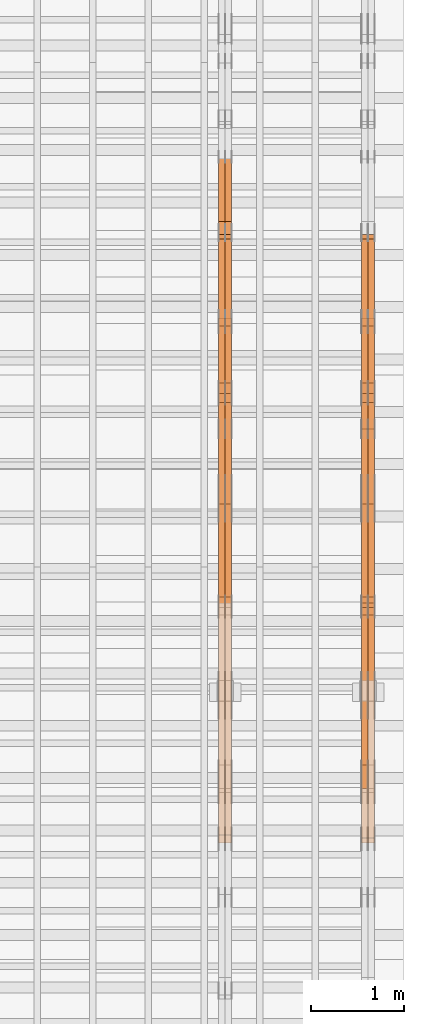
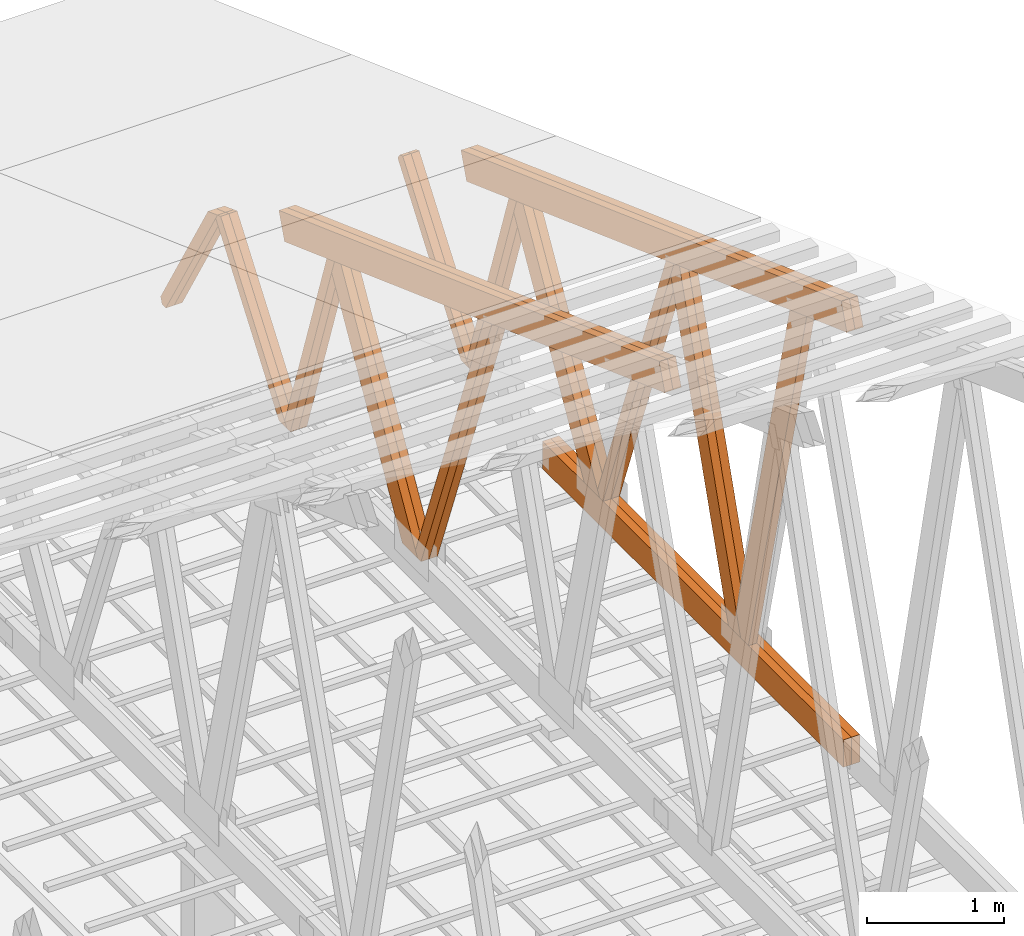
# One storey, part 65 of 189: 27 proxies.
"""IFC2X3 building model written with IfcOpenShell, lengths in millimetres."""

from ifc_helpers import new_model, entity, si_unit, converted_unit, derived_unit, direction, frame, origin, origin_2d_with_axis, place, context, subcontext, project, spatial, polyline, rectangle, outline, extrude, source, transform, mapped, material, type_object, type_shapes, element, save


model = new_model("IFC2X3")

# Units and contexts
model_context = context("Model", 3, precision=0.01, world=origin(), true_north=direction((6.12303176911189e-17, 1.0)))
body_context = subcontext(model_context, "Body", "Model", "MODEL_VIEW")
ifc_project = project(units=[si_unit("LENGTHUNIT", "METRE", prefix="MILLI"), si_unit("AREAUNIT", "SQUARE_METRE"), si_unit("VOLUMEUNIT", "CUBIC_METRE"), converted_unit("PLANEANGLEUNIT", "DEGREE", entity("IfcRatioMeasure", 0.0174532925199433), si_unit("PLANEANGLEUNIT", "RADIAN"), dimensions=[0, 0, 0, 0, 0, 0, 0]), si_unit("MASSUNIT", "GRAM", prefix="KILO"), derived_unit("MASSDENSITYUNIT", [(si_unit("MASSUNIT", "GRAM", prefix="KILO"), 1), (si_unit("LENGTHUNIT", "METRE"), -3)]), si_unit("TIMEUNIT", "SECOND"), si_unit("FREQUENCYUNIT", "HERTZ"), si_unit("THERMODYNAMICTEMPERATUREUNIT", "DEGREE_CELSIUS"), derived_unit("THERMALTRANSMITTANCEUNIT", [(si_unit("MASSUNIT", "GRAM", prefix="KILO"), 1), (si_unit("THERMODYNAMICTEMPERATUREUNIT", "KELVIN"), -1), (si_unit("TIMEUNIT", "SECOND"), -3)]), derived_unit("VOLUMETRICFLOWRATEUNIT", [(si_unit("LENGTHUNIT", "METRE"), 3), (si_unit("TIMEUNIT", "SECOND"), -1)]), si_unit("ELECTRICCURRENTUNIT", "AMPERE"), si_unit("ELECTRICVOLTAGEUNIT", "VOLT"), si_unit("POWERUNIT", "WATT"), si_unit("FORCEUNIT", "NEWTON"), si_unit("ILLUMINANCEUNIT", "LUX"), si_unit("LUMINOUSFLUXUNIT", "LUMEN"), si_unit("LUMINOUSINTENSITYUNIT", "CANDELA"), derived_unit("USERDEFINED", [(si_unit("MASSUNIT", "GRAM", prefix="KILO"), -1), (si_unit("LENGTHUNIT", "METRE"), -2), (si_unit("TIMEUNIT", "SECOND"), 3), (si_unit("LUMINOUSFLUXUNIT", "LUMEN"), 1)]), derived_unit("LINEARVELOCITYUNIT", [(si_unit("LENGTHUNIT", "METRE"), 1), (si_unit("TIMEUNIT", "SECOND"), -1)]), si_unit("PRESSUREUNIT", "PASCAL"), derived_unit("USERDEFINED", [(si_unit("LENGTHUNIT", "METRE"), -2), (si_unit("MASSUNIT", "GRAM", prefix="KILO"), 1), (si_unit("TIMEUNIT", "SECOND"), -2)])], contexts=[model_context])

# Site, building, storey
site_placement = place(None, origin())
site = spatial("IfcSite", under=ifc_project, at=site_placement, CompositionType="ELEMENT")
building_placement = place(site_placement, origin())
building = spatial("IfcBuilding", under=site, at=building_placement, CompositionType="ELEMENT")
storey_placement = place(building_placement, origin())
storey = spatial("IfcBuildingStorey", under=building, at=storey_placement, Name="Default", CompositionType="ELEMENT", Elevation=0.0)

# Proxies
ifc_material_1 = material(Name="IfcSurfaceStyle #272650")
building_element_proxy_type_1 = type_object("IfcBuildingElementProxyType", Name="T1-W1 272648", PredefinedType="NOTDEFINED", material=ifc_material_1)
shared_shape_1 = source(origin(), body_context, "Body", "SweptSolid", [
    extrude(outline(polyline([(-1996.99427801396, -109.999889649051), (1271.09905152223, -109.999889649051), (1448.88120817726, -0.000113190727324008), (1421.70802776002, 109.999946244415), (-2144.69400944554, 109.999946244415), (-1996.99427801396, -109.999889649051)])), frame((1448.88120817726, 110.000265670598, 0.0), z_axis=(0.0, 0.0, 1.0), x_axis=(-1.0, 0.0, 0.0)), (0.0, 0.0, 1.0), 69.9999999999998),
])
type_shapes(building_element_proxy_type_1, [shared_shape_1])
proxy_1_placement = place(building_placement, frame((49770.0, 20558.6774904859, 218.61972674968), z_axis=(-1.0, 0.0, 0.0), x_axis=(0.0, -0.239819839925979, 0.970817410421691)))
element("IfcBuildingElementProxy", 1, at=proxy_1_placement, inside=storey, type_object=building_element_proxy_type_1, material=ifc_material_1, Name="T1-W1", context=body_context, shape_type="MappedRepresentation", body=[
    mapped(shared_shape_1, transform((0.0, 0.0, 0.0), scale=1.0)),
])
ifc_material_2 = material(Name="IfcSurfaceStyle #272452")
building_element_proxy_type_2 = type_object("IfcBuildingElementProxyType", Name="T1-W4 272450", PredefinedType="NOTDEFINED", material=ifc_material_2)
shared_shape_2 = source(origin(), body_context, "Body", "SweptSolid", [
    extrude(outline(polyline([(-1742.90513395849, -84.9997422414737), (1181.3544167489, -84.9997422414737), (1178.19398821251, -0.000208932978430543), (1071.44989130457, 84.999846707963), (-1688.09316230749, 84.999846707963), (-1742.90513395849, -84.9997422414737)])), frame((1181.35452116422, 84.999886337523, 0.0), z_axis=(0.0, 0.0, 1.0), x_axis=(-1.0, 0.0, 0.0)), (0.0, 0.0, 1.0), 69.9999999999998),
])
type_shapes(building_element_proxy_type_2, [shared_shape_2])
proxy_2_placement = place(building_placement, frame((49840.0, 21724.6281517871, 2976.00232464744), z_axis=(-1.0, 0.0, 0.0), x_axis=(0.0, -0.306868406216495, -0.951751953644514)))
element("IfcBuildingElementProxy", 2, at=proxy_2_placement, inside=storey, type_object=building_element_proxy_type_2, material=ifc_material_2, Name="T1-W4", context=body_context, shape_type="MappedRepresentation", body=[
    mapped(shared_shape_2, transform((0.0, 0.0, 0.0), scale=1.0)),
])
ifc_material_3 = material(Name="IfcSurfaceStyle #272386")
building_element_proxy_type_3 = type_object("IfcBuildingElementProxyType", Name="T1-W4 272384", PredefinedType="NOTDEFINED", material=ifc_material_3)
shared_shape_3 = source(origin(), body_context, "Body", "SweptSolid", [
    extrude(outline(polyline([(-1742.90513395849, -84.9997422414737), (1181.3544167489, -84.9997422414737), (1178.19398821251, -0.000208932978430543), (1071.44989130457, 84.999846707963), (-1688.09316230749, 84.999846707963), (-1742.90513395849, -84.9997422414737)])), frame((1181.35452116422, 84.999886337523, 0.0), z_axis=(0.0, 0.0, 1.0), x_axis=(-1.0, 0.0, 0.0)), (0.0, 0.0, 1.0), 69.9999999999998),
])
type_shapes(building_element_proxy_type_3, [shared_shape_3])
proxy_3_placement = place(building_placement, frame((49770.0, 21724.6281517871, 2976.00232464744), z_axis=(-1.0, 0.0, 0.0), x_axis=(0.0, -0.306868406216495, -0.951751953644514)))
element("IfcBuildingElementProxy", 3, at=proxy_3_placement, inside=storey, type_object=building_element_proxy_type_3, material=ifc_material_3, Name="T1-W4", context=body_context, shape_type="MappedRepresentation", body=[
    mapped(shared_shape_3, transform((0.0, 0.0, 0.0), scale=1.0)),
])
ifc_material_4 = material(Name="IfcSurfaceStyle #272188")
building_element_proxy_type_4 = type_object("IfcBuildingElementProxyType", Name="T1-W8 272186", PredefinedType="NOTDEFINED", material=ifc_material_4)
shared_shape_4 = source(origin(), body_context, "Body", "SweptSolid", [
    extrude(outline(polyline([(-1700.10906247918, -47.4998559987011), (1140.60243146647, -47.4998559987011), (1179.56122089033, 0.000120838919977206), (1161.65086478184, 47.4997955792411), (-1781.70545465947, 47.4997955792411), (-1700.10906247918, -47.4998559987011)])), frame((1179.56128464708, 47.5000634692093, 0.0), z_axis=(0.0, 0.0, 1.0), x_axis=(-1.0, 0.0, 0.0)), (0.0, 0.0, 1.0), 69.9999999999998),
])
type_shapes(building_element_proxy_type_4, [shared_shape_4])
proxy_4_placement = place(building_placement, frame((49840.0, 22687.5385403115, 228.241249073207), z_axis=(-1.0, 0.0, 0.0), x_axis=(0.0, -0.352814979177604, 0.93569310698963)))
element("IfcBuildingElementProxy", 4, at=proxy_4_placement, inside=storey, type_object=building_element_proxy_type_4, material=ifc_material_4, Name="T1-W8", context=body_context, shape_type="MappedRepresentation", body=[
    mapped(shared_shape_4, transform((0.0, 0.0, 0.0), scale=1.0)),
])
ifc_material_5 = material(Name="IfcSurfaceStyle #272122")
building_element_proxy_type_5 = type_object("IfcBuildingElementProxyType", Name="T1-W8 272120", PredefinedType="NOTDEFINED", material=ifc_material_5)
shared_shape_5 = source(origin(), body_context, "Body", "SweptSolid", [
    extrude(outline(polyline([(-1700.10906247918, -47.4998559987011), (1140.60243146647, -47.4998559987011), (1179.56122089033, 0.000120838919977206), (1161.65086478184, 47.4997955792411), (-1781.70545465947, 47.4997955792411), (-1700.10906247918, -47.4998559987011)])), frame((1179.56128464708, 47.5000634692093, 0.0), z_axis=(0.0, 0.0, 1.0), x_axis=(-1.0, 0.0, 0.0)), (0.0, 0.0, 1.0), 69.9999999999998),
])
type_shapes(building_element_proxy_type_5, [shared_shape_5])
proxy_5_placement = place(building_placement, frame((49770.0, 22687.5385403115, 228.241249073207), z_axis=(-1.0, 0.0, 0.0), x_axis=(0.0, -0.352814979177604, 0.93569310698963)))
element("IfcBuildingElementProxy", 5, at=proxy_5_placement, inside=storey, type_object=building_element_proxy_type_5, material=ifc_material_5, Name="T1-W8", context=body_context, shape_type="MappedRepresentation", body=[
    mapped(shared_shape_5, transform((0.0, 0.0, 0.0), scale=1.0)),
])
ifc_material_6 = material(Name="IfcSurfaceStyle #271924")
building_element_proxy_type_6 = type_object("IfcBuildingElementProxyType", Name="T1-W2 271922", PredefinedType="NOTDEFINED", material=ifc_material_6)
shared_shape_6 = source(origin(), body_context, "Body", "SweptSolid", [
    extrude(outline(polyline([(-1361.89144606429, -97.5000598486876), (887.613245225805, -97.5000598486876), (904.774262962339, 0.000302345139042259), (818.892339969004, 97.4999086761182), (-1249.38840209286, 97.4999086761182), (-1361.89144606429, -97.5000598486876)])), frame((904.774262962339, 97.5000966763391, 0.0), z_axis=(0.0, 0.0, 1.0), x_axis=(-1.0, 0.0, 0.0)), (0.0, 0.0, 1.0), 69.9999999999999),
])
type_shapes(building_element_proxy_type_6, [shared_shape_6])
proxy_6_placement = place(building_placement, frame((49840.0, 24033.6159173732, 2110.89189244614), z_axis=(-1.0, 0.0, 0.0), x_axis=(0.0, -0.5, -0.866025403784439)))
element("IfcBuildingElementProxy", 6, at=proxy_6_placement, inside=storey, type_object=building_element_proxy_type_6, material=ifc_material_6, Name="T1-W2", context=body_context, shape_type="MappedRepresentation", body=[
    mapped(shared_shape_6, transform((0.0, 0.0, 0.0), scale=1.0)),
])
ifc_material_7 = material(Name="IfcSurfaceStyle #271858")
building_element_proxy_type_7 = type_object("IfcBuildingElementProxyType", Name="T1-W2 271856", PredefinedType="NOTDEFINED", material=ifc_material_7)
shared_shape_7 = source(origin(), body_context, "Body", "SweptSolid", [
    extrude(outline(polyline([(-1361.89144606429, -97.5000598486876), (887.613245225805, -97.5000598486876), (904.774262962339, 0.000302345139042259), (818.892339969004, 97.4999086761182), (-1249.38840209286, 97.4999086761182), (-1361.89144606429, -97.5000598486876)])), frame((904.774262962339, 97.5000966763391, 0.0), z_axis=(0.0, 0.0, 1.0), x_axis=(-1.0, 0.0, 0.0)), (0.0, 0.0, 1.0), 69.9999999999999),
])
type_shapes(building_element_proxy_type_7, [shared_shape_7])
proxy_7_placement = place(building_placement, frame((49770.0, 24033.6159173732, 2110.89189244614), z_axis=(-1.0, 0.0, 0.0), x_axis=(0.0, -0.5, -0.866025403784439)))
element("IfcBuildingElementProxy", 7, at=proxy_7_placement, inside=storey, type_object=building_element_proxy_type_7, material=ifc_material_7, Name="T1-W2", context=body_context, shape_type="MappedRepresentation", body=[
    mapped(shared_shape_7, transform((0.0, 0.0, 0.0), scale=1.0)),
])
ifc_material_8 = material(Name="IfcSurfaceStyle #271660")
building_element_proxy_type_8 = type_object("IfcBuildingElementProxyType", Name="T1-W9 271658", PredefinedType="NOTDEFINED", material=ifc_material_8)
shared_shape_8 = source(origin(), body_context, "Body", "SweptSolid", [
    extrude(outline(polyline([(-1151.44310138162, -47.5000079487596), (776.329826327547, -47.5000079487596), (809.267611644053, -8.1966354137375e-07), (793.242530238244, 47.5000083585914), (-1227.39686682822, 47.5000083585914), (-1151.44310138162, -47.5000079487596)])), frame((809.267685789073, 47.5000083585914, 0.0), z_axis=(0.0, 0.0, 1.0), x_axis=(-1.0, 0.0, 0.0)), (0.0, 0.0, 1.0), 69.9999999999999),
])
type_shapes(building_element_proxy_type_8, [shared_shape_8])
proxy_8_placement = place(building_placement, frame((49840.0, 24600.2198992919, 229.815691184017), z_axis=(-1.0, 0.0, 0.0), x_axis=(0.0, -0.31966811847134, 0.947529574226047)))
element("IfcBuildingElementProxy", 8, at=proxy_8_placement, inside=storey, type_object=building_element_proxy_type_8, material=ifc_material_8, Name="T1-W9", context=body_context, shape_type="MappedRepresentation", body=[
    mapped(shared_shape_8, transform((0.0, 0.0, 0.0), scale=1.0)),
])
ifc_material_9 = material(Name="IfcSurfaceStyle #271594")
building_element_proxy_type_9 = type_object("IfcBuildingElementProxyType", Name="T1-W9 271592", PredefinedType="NOTDEFINED", material=ifc_material_9)
shared_shape_9 = source(origin(), body_context, "Body", "SweptSolid", [
    extrude(outline(polyline([(-1151.44310138162, -47.5000079487596), (776.329826327547, -47.5000079487596), (809.267611644053, -8.1966354137375e-07), (793.242530238244, 47.5000083585914), (-1227.39686682822, 47.5000083585914), (-1151.44310138162, -47.5000079487596)])), frame((809.267685789073, 47.5000083585914, 0.0), z_axis=(0.0, 0.0, 1.0), x_axis=(-1.0, 0.0, 0.0)), (0.0, 0.0, 1.0), 69.9999999999999),
])
type_shapes(building_element_proxy_type_9, [shared_shape_9])
proxy_9_placement = place(building_placement, frame((49770.0, 24600.2198992919, 229.815691184017), z_axis=(-1.0, 0.0, 0.0), x_axis=(0.0, -0.31966811847134, 0.947529574226047)))
element("IfcBuildingElementProxy", 9, at=proxy_9_placement, inside=storey, type_object=building_element_proxy_type_9, material=ifc_material_9, Name="T1-W9", context=body_context, shape_type="MappedRepresentation", body=[
    mapped(shared_shape_9, transform((0.0, 0.0, 0.0), scale=1.0)),
])
ifc_material_10 = material(Name="IfcSurfaceStyle #271396")
building_element_proxy_type_10 = type_object("IfcBuildingElementProxyType", Name="T1-W10 271394", PredefinedType="NOTDEFINED", material=ifc_material_10)
shared_shape_10 = source(origin(), body_context, "Body", "SweptSolid", [
    extrude(outline(polyline([(-993.240970354386, -47.5000757607337), (635.890952815036, -47.5000757607337), (650.068145237537, -1.47580554758164e-05), (629.921374092803, 47.5000831397614), (-922.639501790989, 47.5000831397614), (-993.240970354386, -47.5000757607337)])), frame((650.068173419645, 47.5002811208496, 0.0), z_axis=(0.0, 0.0, 1.0), x_axis=(-1.0, 0.0, 0.0)), (0.0, 0.0, 1.0), 69.9999999999999),
])
type_shapes(building_element_proxy_type_10, [shared_shape_10])
proxy_10_placement = place(building_placement, frame((49840.0, 25701.688098798, 1507.2920009025), z_axis=(-1.0, 0.0, 0.0), x_axis=(0.0, -0.596486092002004, -0.802623412347395)))
element("IfcBuildingElementProxy", 10, at=proxy_10_placement, inside=storey, type_object=building_element_proxy_type_10, material=ifc_material_10, Name="T1-W10", context=body_context, shape_type="MappedRepresentation", body=[
    mapped(shared_shape_10, transform((0.0, 0.0, 0.0), scale=1.0)),
])
ifc_material_11 = material(Name="IfcSurfaceStyle #271330")
building_element_proxy_type_11 = type_object("IfcBuildingElementProxyType", Name="T1-W10 271328", PredefinedType="NOTDEFINED", material=ifc_material_11)
shared_shape_11 = source(origin(), body_context, "Body", "SweptSolid", [
    extrude(outline(polyline([(-993.240970354386, -47.5000757607337), (635.890952815036, -47.5000757607337), (650.068145237537, -1.47580554758164e-05), (629.921374092803, 47.5000831397614), (-922.639501790989, 47.5000831397614), (-993.240970354386, -47.5000757607337)])), frame((650.068173419645, 47.5002811208496, 0.0), z_axis=(0.0, 0.0, 1.0), x_axis=(-1.0, 0.0, 0.0)), (0.0, 0.0, 1.0), 69.9999999999999),
])
type_shapes(building_element_proxy_type_11, [shared_shape_11])
proxy_11_placement = place(building_placement, frame((49770.0, 25701.688098798, 1507.2920009025), z_axis=(-1.0, 0.0, 0.0), x_axis=(0.0, -0.596486092002004, -0.802623412347395)))
element("IfcBuildingElementProxy", 11, at=proxy_11_placement, inside=storey, type_object=building_element_proxy_type_11, material=ifc_material_11, Name="T1-W10", context=body_context, shape_type="MappedRepresentation", body=[
    mapped(shared_shape_11, transform((0.0, 0.0, 0.0), scale=1.0)),
])
ifc_material_12 = material(Name="IfcSurfaceStyle #269848")
building_element_proxy_type_12 = type_object("IfcBuildingElementProxyType", Name="T1-B4 269846", PredefinedType="NOTDEFINED", material=ifc_material_12)
shared_shape_12 = source(origin(), body_context, "Body", "SweptSolid", [
    extrude(rectangle(XDim=4408.2412109375, YDim=245.000000000001, at=origin_2d_with_axis()), frame((2204.12060546875, 122.5, 0.0), z_axis=(0.0, 0.0, 1.0), x_axis=(-1.0, 0.0, 0.0)), (0.0, 0.0, 1.0), 69.9999999999997),
])
type_shapes(building_element_proxy_type_12, [shared_shape_12])
proxy_12_placement = place(building_placement, frame((49840.0, 19161.7587890625, 245.0), z_axis=(-1.0, 0.0, 0.0), x_axis=(0.0, 1.0, 0.0)))
element("IfcBuildingElementProxy", 12, at=proxy_12_placement, inside=storey, type_object=building_element_proxy_type_12, material=ifc_material_12, Name="T1-B4", context=body_context, shape_type="MappedRepresentation", body=[
    mapped(shared_shape_12, transform((0.0, 0.0, 0.0), scale=1.0)),
])
ifc_material_13 = material(Name="IfcSurfaceStyle #269791")
building_element_proxy_type_13 = type_object("IfcBuildingElementProxyType", Name="T1-B4 269789", PredefinedType="NOTDEFINED", material=ifc_material_13)
shared_shape_13 = source(origin(), body_context, "Body", "SweptSolid", [
    extrude(rectangle(XDim=4408.2412109375, YDim=245.000000000001, at=origin_2d_with_axis()), frame((2204.12060546875, 122.5, 0.0), z_axis=(0.0, 0.0, 1.0), x_axis=(-1.0, 0.0, 0.0)), (0.0, 0.0, 1.0), 69.9999999999997),
])
type_shapes(building_element_proxy_type_13, [shared_shape_13])
proxy_13_placement = place(building_placement, frame((49770.0, 19161.7587890625, 245.0), z_axis=(-1.0, 0.0, 0.0), x_axis=(0.0, 1.0, 0.0)))
element("IfcBuildingElementProxy", 13, at=proxy_13_placement, inside=storey, type_object=building_element_proxy_type_13, material=ifc_material_13, Name="T1-B4", context=body_context, shape_type="MappedRepresentation", body=[
    mapped(shared_shape_13, transform((0.0, 0.0, 0.0), scale=1.0)),
])
ifc_material_14 = material(Name="IfcSurfaceStyle #268804")
building_element_proxy_type_14 = type_object("IfcBuildingElementProxyType", Name="T1-T1 268802", PredefinedType="NOTDEFINED", material=ifc_material_14)
shared_shape_14 = source(origin(), body_context, "Body", "SweptSolid", [
    extrude(outline(polyline([(-2964.99982426074, -122.499947708046), (2964.99981923522, -122.499947708046), (2964.99984513599, 122.499947708046), (-2964.99984011047, 122.499947708046), (-2964.99982426074, -122.499947708046)])), frame((2964.99984513599, 122.499998966405, 0.0), z_axis=(0.0, 0.0, 1.0), x_axis=(-1.0, 0.0, 0.0)), (0.0, 0.0, 1.0), 69.9999999999996),
])
type_shapes(building_element_proxy_type_14, [shared_shape_14])
proxy_14_placement = place(building_placement, frame((49840.0, 24681.3398262186, 1893.12531804384), z_axis=(-1.0, 0.0, 0.0), x_axis=(0.0, -0.939692620785908, 0.342020143325669)))
element("IfcBuildingElementProxy", 14, at=proxy_14_placement, inside=storey, type_object=building_element_proxy_type_14, material=ifc_material_14, Name="T1-T1", context=body_context, shape_type="MappedRepresentation", body=[
    mapped(shared_shape_14, transform((0.0, 0.0, 0.0), scale=1.0)),
])
ifc_material_15 = material(Name="IfcSurfaceStyle #268747")
building_element_proxy_type_15 = type_object("IfcBuildingElementProxyType", Name="T1-T1 268745", PredefinedType="NOTDEFINED", material=ifc_material_15)
shared_shape_15 = source(origin(), body_context, "Body", "SweptSolid", [
    extrude(outline(polyline([(-2964.99982426074, -122.499947708046), (2964.99981923522, -122.499947708046), (2964.99984513599, 122.499947708046), (-2964.99984011047, 122.499947708046), (-2964.99982426074, -122.499947708046)])), frame((2964.99984513599, 122.499998966405, 0.0), z_axis=(0.0, 0.0, 1.0), x_axis=(-1.0, 0.0, 0.0)), (0.0, 0.0, 1.0), 69.9999999999996),
])
type_shapes(building_element_proxy_type_15, [shared_shape_15])
proxy_15_placement = place(building_placement, frame((49770.0, 24681.3398262186, 1893.12531804384), z_axis=(-1.0, 0.0, 0.0), x_axis=(0.0, -0.939692620785908, 0.342020143325669)))
element("IfcBuildingElementProxy", 15, at=proxy_15_placement, inside=storey, type_object=building_element_proxy_type_15, material=ifc_material_15, Name="T1-T1", context=body_context, shape_type="MappedRepresentation", body=[
    mapped(shared_shape_15, transform((0.0, 0.0, 0.0), scale=1.0)),
])
ifc_material_16 = material(Name="IfcSurfaceStyle #256398")
building_element_proxy_type_16 = type_object("IfcBuildingElementProxyType", Name="T1-W8 256396", PredefinedType="NOTDEFINED", material=ifc_material_16)
shared_shape_16 = source(origin(), body_context, "Body", "SweptSolid", [
    extrude(outline(polyline([(-1700.10906247918, -47.4998559987011), (1140.60243146647, -47.4998559987011), (1179.56122089033, 0.000120838919977206), (1161.65086478184, 47.4997955792411), (-1781.70545465947, 47.4997955792411), (-1700.10906247918, -47.4998559987011)])), frame((1179.56128464708, 47.5000634692093, 0.0), z_axis=(0.0, 0.0, 1.0), x_axis=(-1.0, 0.0, 0.0)), (0.0, 0.0, 1.0), 69.9999999999998),
])
type_shapes(building_element_proxy_type_16, [shared_shape_16])
proxy_16_placement = place(building_placement, frame((48300.0, 22687.5385403115, 228.241249073207), z_axis=(-1.0, 0.0, 0.0), x_axis=(0.0, -0.352814979177604, 0.93569310698963)))
element("IfcBuildingElementProxy", 16, at=proxy_16_placement, inside=storey, type_object=building_element_proxy_type_16, material=ifc_material_16, Name="T1-W8", context=body_context, shape_type="MappedRepresentation", body=[
    mapped(shared_shape_16, transform((0.0, 0.0, 0.0), scale=1.0)),
])
ifc_material_17 = material(Name="IfcSurfaceStyle #256332")
building_element_proxy_type_17 = type_object("IfcBuildingElementProxyType", Name="T1-W8 256330", PredefinedType="NOTDEFINED", material=ifc_material_17)
shared_shape_17 = source(origin(), body_context, "Body", "SweptSolid", [
    extrude(outline(polyline([(-1700.10906247918, -47.4998559987011), (1140.60243146647, -47.4998559987011), (1179.56122089033, 0.000120838919977206), (1161.65086478184, 47.4997955792411), (-1781.70545465947, 47.4997955792411), (-1700.10906247918, -47.4998559987011)])), frame((1179.56128464708, 47.5000634692093, 0.0), z_axis=(0.0, 0.0, 1.0), x_axis=(-1.0, 0.0, 0.0)), (0.0, 0.0, 1.0), 69.9999999999998),
])
type_shapes(building_element_proxy_type_17, [shared_shape_17])
proxy_17_placement = place(building_placement, frame((48230.0, 22687.5385403115, 228.241249073207), z_axis=(-1.0, 0.0, 0.0), x_axis=(0.0, -0.352814979177604, 0.93569310698963)))
element("IfcBuildingElementProxy", 17, at=proxy_17_placement, inside=storey, type_object=building_element_proxy_type_17, material=ifc_material_17, Name="T1-W8", context=body_context, shape_type="MappedRepresentation", body=[
    mapped(shared_shape_17, transform((0.0, 0.0, 0.0), scale=1.0)),
])
ifc_material_18 = material(Name="IfcSurfaceStyle #256134")
building_element_proxy_type_18 = type_object("IfcBuildingElementProxyType", Name="T1-W2 256132", PredefinedType="NOTDEFINED", material=ifc_material_18)
shared_shape_18 = source(origin(), body_context, "Body", "SweptSolid", [
    extrude(outline(polyline([(-1361.89144606429, -97.5000598486876), (887.613245225805, -97.5000598486876), (904.774262962339, 0.000302345139042259), (818.892339969004, 97.4999086761182), (-1249.38840209286, 97.4999086761182), (-1361.89144606429, -97.5000598486876)])), frame((904.774262962339, 97.5000966763391, 0.0), z_axis=(0.0, 0.0, 1.0), x_axis=(-1.0, 0.0, 0.0)), (0.0, 0.0, 1.0), 69.9999999999999),
])
type_shapes(building_element_proxy_type_18, [shared_shape_18])
proxy_18_placement = place(building_placement, frame((48300.0, 24033.6159173732, 2110.89189244614), z_axis=(-1.0, 0.0, 0.0), x_axis=(0.0, -0.5, -0.866025403784439)))
element("IfcBuildingElementProxy", 18, at=proxy_18_placement, inside=storey, type_object=building_element_proxy_type_18, material=ifc_material_18, Name="T1-W2", context=body_context, shape_type="MappedRepresentation", body=[
    mapped(shared_shape_18, transform((0.0, 0.0, 0.0), scale=1.0)),
])
ifc_material_19 = material(Name="IfcSurfaceStyle #256068")
building_element_proxy_type_19 = type_object("IfcBuildingElementProxyType", Name="T1-W2 256066", PredefinedType="NOTDEFINED", material=ifc_material_19)
shared_shape_19 = source(origin(), body_context, "Body", "SweptSolid", [
    extrude(outline(polyline([(-1361.89144606429, -97.5000598486876), (887.613245225805, -97.5000598486876), (904.774262962339, 0.000302345139042259), (818.892339969004, 97.4999086761182), (-1249.38840209286, 97.4999086761182), (-1361.89144606429, -97.5000598486876)])), frame((904.774262962339, 97.5000966763391, 0.0), z_axis=(0.0, 0.0, 1.0), x_axis=(-1.0, 0.0, 0.0)), (0.0, 0.0, 1.0), 69.9999999999999),
])
type_shapes(building_element_proxy_type_19, [shared_shape_19])
proxy_19_placement = place(building_placement, frame((48230.0, 24033.6159173732, 2110.89189244614), z_axis=(-1.0, 0.0, 0.0), x_axis=(0.0, -0.5, -0.866025403784439)))
element("IfcBuildingElementProxy", 19, at=proxy_19_placement, inside=storey, type_object=building_element_proxy_type_19, material=ifc_material_19, Name="T1-W2", context=body_context, shape_type="MappedRepresentation", body=[
    mapped(shared_shape_19, transform((0.0, 0.0, 0.0), scale=1.0)),
])
ifc_material_20 = material(Name="IfcSurfaceStyle #255870")
building_element_proxy_type_20 = type_object("IfcBuildingElementProxyType", Name="T1-W9 255868", PredefinedType="NOTDEFINED", material=ifc_material_20)
shared_shape_20 = source(origin(), body_context, "Body", "SweptSolid", [
    extrude(outline(polyline([(-1151.44310138162, -47.5000079487596), (776.329826327547, -47.5000079487596), (809.267611644053, -8.1966354137375e-07), (793.242530238244, 47.5000083585914), (-1227.39686682822, 47.5000083585914), (-1151.44310138162, -47.5000079487596)])), frame((809.267685789073, 47.5000083585914, 0.0), z_axis=(0.0, 0.0, 1.0), x_axis=(-1.0, 0.0, 0.0)), (0.0, 0.0, 1.0), 69.9999999999999),
])
type_shapes(building_element_proxy_type_20, [shared_shape_20])
proxy_20_placement = place(building_placement, frame((48300.0, 24600.2198992919, 229.815691184017), z_axis=(-1.0, 0.0, 0.0), x_axis=(0.0, -0.31966811847134, 0.947529574226047)))
element("IfcBuildingElementProxy", 20, at=proxy_20_placement, inside=storey, type_object=building_element_proxy_type_20, material=ifc_material_20, Name="T1-W9", context=body_context, shape_type="MappedRepresentation", body=[
    mapped(shared_shape_20, transform((0.0, 0.0, 0.0), scale=1.0)),
])
ifc_material_21 = material(Name="IfcSurfaceStyle #255804")
building_element_proxy_type_21 = type_object("IfcBuildingElementProxyType", Name="T1-W9 255802", PredefinedType="NOTDEFINED", material=ifc_material_21)
shared_shape_21 = source(origin(), body_context, "Body", "SweptSolid", [
    extrude(outline(polyline([(-1151.44310138162, -47.5000079487596), (776.329826327547, -47.5000079487596), (809.267611644053, -8.1966354137375e-07), (793.242530238244, 47.5000083585914), (-1227.39686682822, 47.5000083585914), (-1151.44310138162, -47.5000079487596)])), frame((809.267685789073, 47.5000083585914, 0.0), z_axis=(0.0, 0.0, 1.0), x_axis=(-1.0, 0.0, 0.0)), (0.0, 0.0, 1.0), 69.9999999999999),
])
type_shapes(building_element_proxy_type_21, [shared_shape_21])
proxy_21_placement = place(building_placement, frame((48230.0, 24600.2198992919, 229.815691184017), z_axis=(-1.0, 0.0, 0.0), x_axis=(0.0, -0.31966811847134, 0.947529574226047)))
element("IfcBuildingElementProxy", 21, at=proxy_21_placement, inside=storey, type_object=building_element_proxy_type_21, material=ifc_material_21, Name="T1-W9", context=body_context, shape_type="MappedRepresentation", body=[
    mapped(shared_shape_21, transform((0.0, 0.0, 0.0), scale=1.0)),
])
ifc_material_22 = material(Name="IfcSurfaceStyle #255606")
building_element_proxy_type_22 = type_object("IfcBuildingElementProxyType", Name="T1-W10 255604", PredefinedType="NOTDEFINED", material=ifc_material_22)
shared_shape_22 = source(origin(), body_context, "Body", "SweptSolid", [
    extrude(outline(polyline([(-993.240970354386, -47.5000757607337), (635.890952815036, -47.5000757607337), (650.068145237537, -1.47580554758164e-05), (629.921374092803, 47.5000831397614), (-922.639501790989, 47.5000831397614), (-993.240970354386, -47.5000757607337)])), frame((650.068173419645, 47.5002811208496, 0.0), z_axis=(0.0, 0.0, 1.0), x_axis=(-1.0, 0.0, 0.0)), (0.0, 0.0, 1.0), 69.9999999999999),
])
type_shapes(building_element_proxy_type_22, [shared_shape_22])
proxy_22_placement = place(building_placement, frame((48300.0, 25701.688098798, 1507.2920009025), z_axis=(-1.0, 0.0, 0.0), x_axis=(0.0, -0.596486092002004, -0.802623412347395)))
element("IfcBuildingElementProxy", 22, at=proxy_22_placement, inside=storey, type_object=building_element_proxy_type_22, material=ifc_material_22, Name="T1-W10", context=body_context, shape_type="MappedRepresentation", body=[
    mapped(shared_shape_22, transform((0.0, 0.0, 0.0), scale=1.0)),
])
ifc_material_23 = material(Name="IfcSurfaceStyle #255540")
building_element_proxy_type_23 = type_object("IfcBuildingElementProxyType", Name="T1-W10 255538", PredefinedType="NOTDEFINED", material=ifc_material_23)
shared_shape_23 = source(origin(), body_context, "Body", "SweptSolid", [
    extrude(outline(polyline([(-993.240970354386, -47.5000757607337), (635.890952815036, -47.5000757607337), (650.068145237537, -1.47580554758164e-05), (629.921374092803, 47.5000831397614), (-922.639501790989, 47.5000831397614), (-993.240970354386, -47.5000757607337)])), frame((650.068173419645, 47.5002811208496, 0.0), z_axis=(0.0, 0.0, 1.0), x_axis=(-1.0, 0.0, 0.0)), (0.0, 0.0, 1.0), 69.9999999999999),
])
type_shapes(building_element_proxy_type_23, [shared_shape_23])
proxy_23_placement = place(building_placement, frame((48230.0, 25701.688098798, 1507.2920009025), z_axis=(-1.0, 0.0, 0.0), x_axis=(0.0, -0.596486092002004, -0.802623412347395)))
element("IfcBuildingElementProxy", 23, at=proxy_23_placement, inside=storey, type_object=building_element_proxy_type_23, material=ifc_material_23, Name="T1-W10", context=body_context, shape_type="MappedRepresentation", body=[
    mapped(shared_shape_23, transform((0.0, 0.0, 0.0), scale=1.0)),
])
ifc_material_24 = material(Name="IfcSurfaceStyle #255342")
building_element_proxy_type_24 = type_object("IfcBuildingElementProxyType", Name="T1-W11 255340", PredefinedType="NOTDEFINED", material=ifc_material_24)
shared_shape_24 = source(origin(), body_context, "Body", "SweptSolid", [
    extrude(outline(polyline([(-809.410890003667, -47.5000077306544), (561.624013869753, -47.5000077306544), (599.944137054867, -7.52294285037536e-05), (572.078784657538, 47.5000453453687), (-924.236045578491, 47.5000453453687), (-809.410890003667, -47.5000077306544)])), frame((599.944137054867, 47.5000453453687, 0.0), z_axis=(0.0, 0.0, 1.0), x_axis=(-1.0, 0.0, 0.0)), (0.0, 0.0, 1.0), 69.9999999999999),
])
type_shapes(building_element_proxy_type_24, [shared_shape_24])
proxy_24_placement = place(building_placement, frame((48300.0, 26434.7921369083, 220.965133687368), z_axis=(-1.0, 0.0, 0.0), x_axis=(0.0, -0.505995901100603, 0.862535882192381)))
element("IfcBuildingElementProxy", 24, at=proxy_24_placement, inside=storey, type_object=building_element_proxy_type_24, material=ifc_material_24, Name="T1-W11", context=body_context, shape_type="MappedRepresentation", body=[
    mapped(shared_shape_24, transform((0.0, 0.0, 0.0), scale=1.0)),
])
ifc_material_25 = material(Name="IfcSurfaceStyle #255276")
building_element_proxy_type_25 = type_object("IfcBuildingElementProxyType", Name="T1-W11 255274", PredefinedType="NOTDEFINED", material=ifc_material_25)
shared_shape_25 = source(origin(), body_context, "Body", "SweptSolid", [
    extrude(outline(polyline([(-809.410890003667, -47.5000077306544), (561.624013869753, -47.5000077306544), (599.944137054867, -7.52294285037536e-05), (572.078784657538, 47.5000453453687), (-924.236045578491, 47.5000453453687), (-809.410890003667, -47.5000077306544)])), frame((599.944137054867, 47.5000453453687, 0.0), z_axis=(0.0, 0.0, 1.0), x_axis=(-1.0, 0.0, 0.0)), (0.0, 0.0, 1.0), 69.9999999999999),
])
type_shapes(building_element_proxy_type_25, [shared_shape_25])
proxy_25_placement = place(building_placement, frame((48230.0, 26434.7921369083, 220.965133687368), z_axis=(-1.0, 0.0, 0.0), x_axis=(0.0, -0.505995901100603, 0.862535882192381)))
element("IfcBuildingElementProxy", 25, at=proxy_25_placement, inside=storey, type_object=building_element_proxy_type_25, material=ifc_material_25, Name="T1-W11", context=body_context, shape_type="MappedRepresentation", body=[
    mapped(shared_shape_25, transform((0.0, 0.0, 0.0), scale=1.0)),
])
ifc_material_26 = material(Name="IfcSurfaceStyle #253014")
building_element_proxy_type_26 = type_object("IfcBuildingElementProxyType", Name="T1-T1 253012", PredefinedType="NOTDEFINED", material=ifc_material_26)
shared_shape_26 = source(origin(), body_context, "Body", "SweptSolid", [
    extrude(outline(polyline([(-2964.99982426074, -122.499947708046), (2964.99981923522, -122.499947708046), (2964.99984513599, 122.499947708046), (-2964.99984011047, 122.499947708046), (-2964.99982426074, -122.499947708046)])), frame((2964.99984513599, 122.499998966405, 0.0), z_axis=(0.0, 0.0, 1.0), x_axis=(-1.0, 0.0, 0.0)), (0.0, 0.0, 1.0), 69.9999999999996),
])
type_shapes(building_element_proxy_type_26, [shared_shape_26])
proxy_26_placement = place(building_placement, frame((48300.0, 24681.3398262186, 1893.12531804384), z_axis=(-1.0, 0.0, 0.0), x_axis=(0.0, -0.939692620785908, 0.342020143325669)))
element("IfcBuildingElementProxy", 26, at=proxy_26_placement, inside=storey, type_object=building_element_proxy_type_26, material=ifc_material_26, Name="T1-T1", context=body_context, shape_type="MappedRepresentation", body=[
    mapped(shared_shape_26, transform((0.0, 0.0, 0.0), scale=1.0)),
])
ifc_material_27 = material(Name="IfcSurfaceStyle #252957")
building_element_proxy_type_27 = type_object("IfcBuildingElementProxyType", Name="T1-T1 252955", PredefinedType="NOTDEFINED", material=ifc_material_27)
shared_shape_27 = source(origin(), body_context, "Body", "SweptSolid", [
    extrude(outline(polyline([(-2964.99982426074, -122.499947708046), (2964.99981923522, -122.499947708046), (2964.99984513599, 122.499947708046), (-2964.99984011047, 122.499947708046), (-2964.99982426074, -122.499947708046)])), frame((2964.99984513599, 122.499998966405, 0.0), z_axis=(0.0, 0.0, 1.0), x_axis=(-1.0, 0.0, 0.0)), (0.0, 0.0, 1.0), 69.9999999999996),
])
type_shapes(building_element_proxy_type_27, [shared_shape_27])
proxy_27_placement = place(building_placement, frame((48230.0, 24681.3398262186, 1893.12531804384), z_axis=(-1.0, 0.0, 0.0), x_axis=(0.0, -0.939692620785908, 0.342020143325669)))
element("IfcBuildingElementProxy", 27, at=proxy_27_placement, inside=storey, type_object=building_element_proxy_type_27, material=ifc_material_27, Name="T1-T1", context=body_context, shape_type="MappedRepresentation", body=[
    mapped(shared_shape_27, transform((0.0, 0.0, 0.0), scale=1.0)),
])

save(model, "model.ifc")
